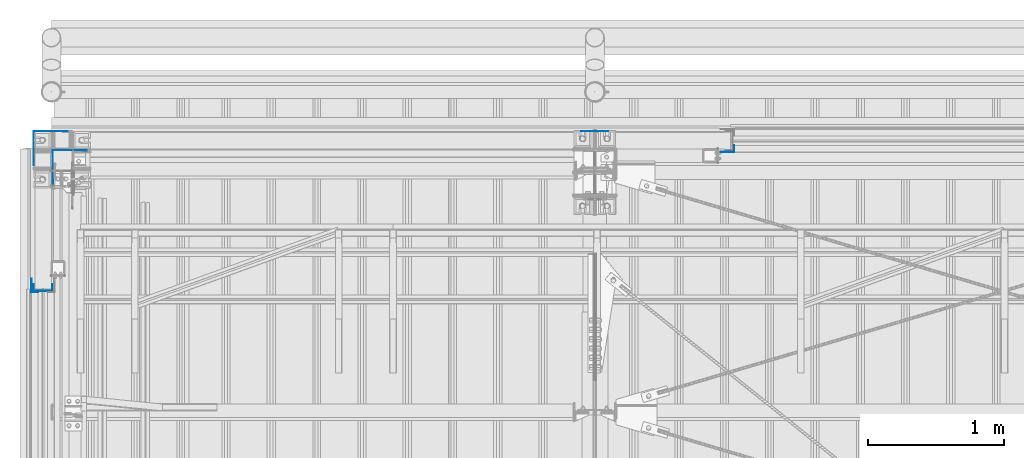
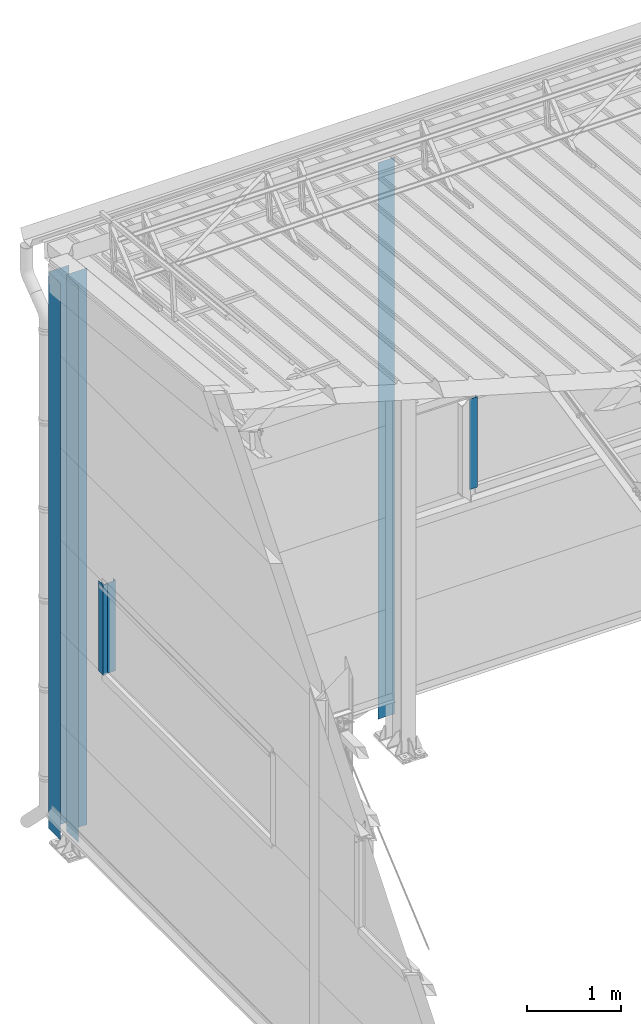
# One storey, part 8 of 709: 6 columns, 6 elements without a shape of their own.
"""IFC4 building model written with IfcOpenShell, lengths in millimetres."""

from ifc_helpers import new_model, si_unit, direction, frame, origin_with_axes, place, context, subcontext, project, spatial, line, indexed_curve, outline, extrude, material, element, aggregate, save


model = new_model("IFC4")

# Units and contexts
model_context = context("Model", 3, precision=0.2, world=origin_with_axes(), true_north=direction((0.0, 1.0)))
body_context = subcontext(model_context, "Body", "Model", "MODEL_VIEW")
ifc_project = project(units=[si_unit("LENGTHUNIT", "METRE", prefix="MILLI"), si_unit("AREAUNIT", "SQUARE_METRE"), si_unit("VOLUMEUNIT", "CUBIC_METRE"), si_unit("MASSUNIT", "GRAM", prefix="KILO"), si_unit("TIMEUNIT", "SECOND"), si_unit("PLANEANGLEUNIT", "RADIAN"), si_unit("SOLIDANGLEUNIT", "STERADIAN"), si_unit("THERMODYNAMICTEMPERATUREUNIT", "DEGREE_CELSIUS"), si_unit("LUMINOUSINTENSITYUNIT", "LUMEN")], contexts=[model_context])

# Site, building, storey
site_placement = place(None, origin_with_axes())
site = spatial("IfcSite", under=ifc_project, at=site_placement, CompositionType="ELEMENT")
building_placement = place(site_placement, origin_with_axes())
building = spatial("IfcBuilding", under=site, at=building_placement, Name="Undefined", CompositionType="ELEMENT")
storey_placement = place(building_placement, origin_with_axes())
storey = spatial("IfcBuildingStorey", under=building, at=storey_placement, Name="Undefined", CompositionType="ELEMENT", Elevation=0.0)

# Assembly, column
assembly_1_placement = place(storey_placement, frame((5025.0, 22001.0, 2700.0), z_axis=(0.0, -1.0, 0.0), x_axis=(0.0, 0.0, 1.0)))
assembly_1 = element("IfcElementAssembly", 1, at=assembly_1_placement, inside=storey)
ifc_material = material(Name="Steel_Undefined", Category="STEEL")
column_1_placement = place(assembly_1_placement, origin_with_axes())
column_1 = element("IfcColumn", 2, at=column_1_placement, material=ifc_material, context=body_context, shape_type="SolidModel", body=[
    extrude(outline(indexed_curve([(-25.0, -1.0), (25.0, -1.0), (25.0, 99.0), (23.0, 99.0), (23.0, 1.0), (-25.0, 1.0)], segments=[line(1, 2, 3, 4, 5, 6, 1)])), frame((0.0, 0.0, 0.0), z_axis=(-1.0, 0.0, 0.0), x_axis=(0.0, 0.0, 1.0)), (0.0, 0.0, -1.0), 1170.0),
])
aggregate(assembly_1, [column_1])

assembly_2_placement = place(storey_placement, frame((-130.0, 22130.0, 0.0), z_axis=(1.0, 0.0, 0.0), x_axis=(0.0, 0.0, 1.0)))
assembly_2 = element("IfcElementAssembly", 3, at=assembly_2_placement, inside=storey)
column_2_placement = place(assembly_2_placement, origin_with_axes())
column_2 = element("IfcColumn", 4, at=column_2_placement, material=ifc_material, context=body_context, shape_type="SolidModel", body=[
    extrude(outline(indexed_curve([(0.0, 0.0), (250.0, 0.0), (250.0, 3.0), (220.0, 3.0), (220.0, 2.0), (249.0, 2.0), (249.0, 1.0), (1.0, 1.0), (1.0, 249.0), (2.0, 249.0), (2.0, 220.0), (3.0, 220.0), (3.0, 250.0), (0.0, 250.0)], segments=[line(1, 2, 3, 4, 5, 6, 7, 8, 9, 10, 11, 12, 13, 14, 1)])), frame((0.0, 0.0, 0.0), z_axis=(-1.0, 0.0, 0.0), x_axis=(0.0, 0.0, 1.0)), (0.0, 0.0, -1.0), 7196.92297),
])
aggregate(assembly_2, [column_2])

assembly_3_placement = place(storey_placement, frame((10.0, 21990.0, 0.0), z_axis=(1.0, 0.0, 0.0), x_axis=(0.0, 0.0, 1.0)))
assembly_3 = element("IfcElementAssembly", 5, at=assembly_3_placement, inside=storey)
column_3_placement = place(assembly_3_placement, origin_with_axes())
column_3 = element("IfcColumn", 6, at=column_3_placement, material=ifc_material, context=body_context, shape_type="SolidModel", body=[
    extrude(outline(indexed_curve([(0.0, 0.0), (250.0, 0.0), (250.0, 3.0), (220.0, 3.0), (220.0, 2.0), (249.0, 2.0), (249.0, 1.0), (1.0, 1.0), (1.0, 249.0), (2.0, 249.0), (2.0, 220.0), (3.0, 220.0), (3.0, 250.0), (0.0, 250.0)], segments=[line(1, 2, 3, 4, 5, 6, 7, 8, 9, 10, 11, 12, 13, 14, 1)])), frame((0.0, 0.0, 0.0), z_axis=(-1.0, 0.0, 0.0), x_axis=(0.0, 0.0, 1.0)), (0.0, 0.0, -1.0), 7196.92297),
])
aggregate(assembly_3, [column_3])

assembly_4_placement = place(storey_placement, frame((4000.0, 22130.0, 0.0), z_axis=(0.0, -1.0, 0.0), x_axis=(0.0, 0.0, 1.0)))
assembly_4 = element("IfcElementAssembly", 7, at=assembly_4_placement, inside=storey)
column_4_placement = place(assembly_4_placement, origin_with_axes())
column_4 = element("IfcColumn", 8, at=column_4_placement, material=ifc_material, context=body_context, shape_type="SolidModel", body=[
    extrude(outline(indexed_curve([(-0.375, -100.0), (1.245, -100.0), (1.245, -50.0), (0.495, -50.0), (0.495, -99.25), (0.375, -99.25), (0.375, 99.25), (0.495, 99.25), (0.495, 50.0), (1.245, 50.0), (1.245, 100.0), (-0.375, 100.0)], segments=[line(1, 2, 3, 4, 5, 6, 7, 8, 9, 10, 11, 12, 1)])), frame((0.0, 0.0, 0.0), z_axis=(-1.0, 0.0, 0.0), x_axis=(0.0, 0.0, 1.0)), (0.0, 0.0, -1.0), 7196.92297),
])
aggregate(assembly_4, [column_4])

assembly_5_placement = place(storey_placement, frame((-60.0, 20980.0, 2700.0), z_axis=(1.0, 0.0, 0.0), x_axis=(0.0, 0.0, 1.0)))
assembly_5 = element("IfcElementAssembly", 9, at=assembly_5_placement, inside=storey)
column_5_placement = place(assembly_5_placement, origin_with_axes())
column_5 = element("IfcColumn", 10, at=column_5_placement, material=ifc_material, context=body_context, shape_type="SolidModel", body=[
    extrude(outline(indexed_curve([(-70.0, -25.0), (-68.0, -25.0), (-68.0, 23.0), (68.0, 23.0), (68.0, -25.0), (70.0, -25.0), (70.0, 25.0), (-70.0, 25.0)], segments=[line(1, 2, 3, 4, 5, 6, 7, 8, 1)])), frame((0.0, 0.0, 0.0), z_axis=(-1.0, 0.0, 0.0), x_axis=(0.0, 0.0, 1.0)), (0.0, 0.0, -1.0), 1170.0),
])
aggregate(assembly_5, [column_5])

assembly_6_placement = place(storey_placement, frame((-121.0, 20945.0, 2700.0), z_axis=(-1.0, 0.0, 0.0), x_axis=(0.0, 0.0, 1.0)))
assembly_6 = element("IfcElementAssembly", 11, at=assembly_6_placement, inside=storey)
column_6_placement = place(assembly_6_placement, origin_with_axes())
column_6 = element("IfcColumn", 12, at=column_6_placement, material=ifc_material, context=body_context, shape_type="SolidModel", body=[
    extrude(outline(indexed_curve([(-25.0, -1.0), (25.0, -1.0), (25.0, 99.0), (23.0, 99.0), (23.0, 1.0), (-25.0, 1.0)], segments=[line(1, 2, 3, 4, 5, 6, 1)])), frame((0.0, 0.0, 0.0), z_axis=(-1.0, 0.0, 0.0), x_axis=(0.0, 0.0, 1.0)), (0.0, 0.0, -1.0), 1170.0),
])
aggregate(assembly_6, [column_6])

save(model, "model.ifc")
